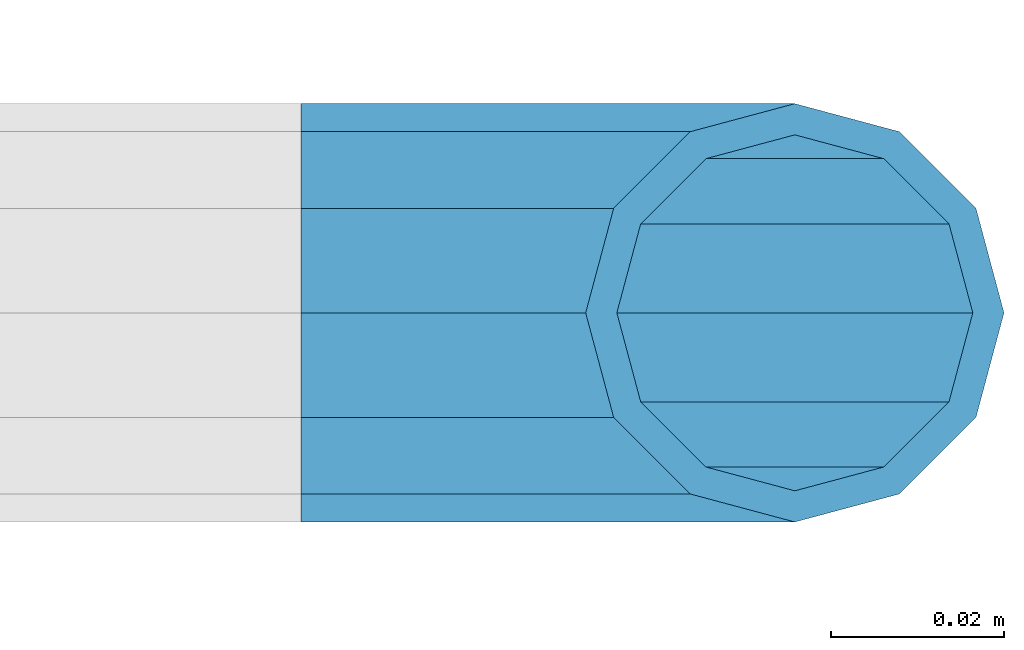
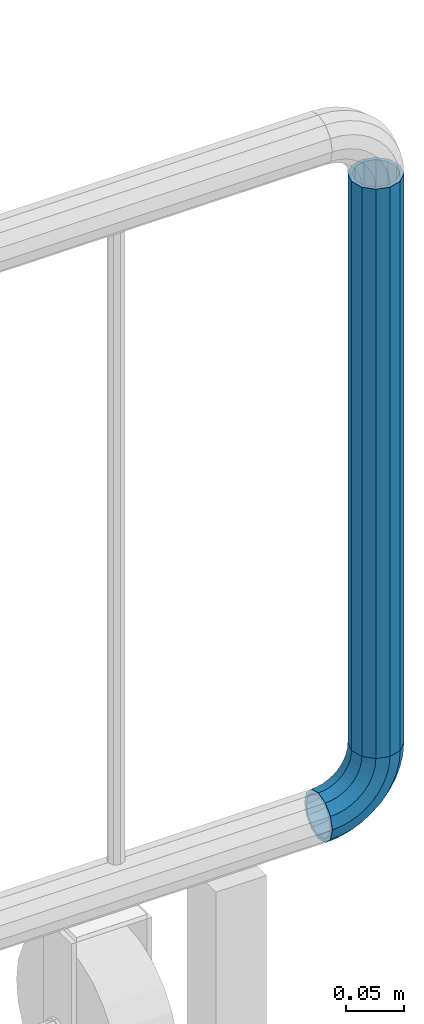
# One storey, part 147 of 208: 1 beam, 1 member.
"""IFC2X3 building model written with IfcOpenShell, lengths in millimetres."""

import ifcopenshell
import ifcopenshell.guid

model = None  # the IFC model being written
_history = None  # IfcOwnerHistory: only IFC2X3 demands one
_inside = {}  # id of a spatial element -> (the spatial element, [elements in it])
_under = {}  # id of a project, library or spatial element -> (it, [spatial elements below it])
_declared = {}  # id of a project -> (the project, [libraries it declares])
_typed = {}  # id of a type object -> (the type object, [elements of that type])
_made_of = {}  # id of a material, layer set ... -> (it, [elements and type objects made of it])


def new_model(schema):
    """Start an empty IFC model of exactly this schema.

    Asked for "IFC4X3", IfcOpenShell would pick the latest addendum, in which some entities
    have other attributes; the version numbers below select the first issue.
    IFC2X3 requires an IfcOwnerHistory on every rooted entity: one is made here for all.
    """
    global model, _history
    if schema == "IFC4X3":
        model = ifcopenshell.file(schema_version=(4, 3, 0, 0))
    else:
        model = ifcopenshell.file(schema=schema)
    _inside.clear()
    _under.clear()
    _declared.clear()
    _typed.clear()
    _made_of.clear()
    _history = None
    if model.schema == "IFC2X3":
        org = make("IfcOrganization", Name="unknown")
        user = make(
            "IfcPersonAndOrganization",
            ThePerson=make("IfcPerson", FamilyName="unknown"),
            TheOrganization=org,
        )
        app = make(
            "IfcApplication",
            ApplicationDeveloper=org,
            Version="unknown",
            ApplicationFullName="unknown",
            ApplicationIdentifier="unknown",
        )
        _history = make(
            "IfcOwnerHistory",
            OwningUser=user,
            OwningApplication=app,
            ChangeAction="ADDED",
            CreationDate=0,
        )
    return model


def make(cls, **values):
    """One entity of the class cls with the attributes given. An attribute that is None is left unset."""
    return model.create_entity(
        cls, **{name: value for name, value in values.items() if value is not None}
    )


def rooted(cls, **values):
    """An entity with a GlobalId (a new one), such as an element, a storey or a relation."""
    return make(cls, GlobalId=ifcopenshell.guid.new(), OwnerHistory=_history, **values)


def si_unit(unit_type, name, prefix=None):
    """IfcSIUnit, for example si_unit("LENGTHUNIT", "METRE", prefix="MILLI")."""
    return make("IfcSIUnit", UnitType=unit_type, Prefix=prefix, Name=name)


def assignment(units):
    """IfcUnitAssignment: the units of a project."""
    return None if units is None else make("IfcUnitAssignment", Units=units)


def point(xyz):
    """IfcCartesianPoint."""
    return None if xyz is None else make("IfcCartesianPoint", Coordinates=xyz)


def direction(xyz):
    """IfcDirection."""
    return None if xyz is None else make("IfcDirection", DirectionRatios=xyz)


def frame(location, z_axis=None, x_axis=None):
    """IfcAxis2Placement3D, a coordinate frame: its origin and axes. An axis left out is left unset."""
    return make(
        "IfcAxis2Placement3D",
        Location=point(location),
        Axis=direction(z_axis),
        RefDirection=direction(x_axis),
    )


def origin_with_axes():
    """The frame at (0, 0, 0) with the z axis (0, 0, 1) and the x axis (1, 0, 0) written out."""
    return frame((0.0, 0.0, 0.0), z_axis=(0.0, 0.0, 1.0), x_axis=(1.0, 0.0, 0.0))


def place(relative_to, where):
    """IfcLocalPlacement: puts the frame where relative to a parent placement (None: the world)."""
    return make(
        "IfcLocalPlacement", PlacementRelTo=relative_to, RelativePlacement=where
    )


def context(
    kind, dimensions, precision=None, world=None, true_north=None, identifier=None
):
    """IfcGeometricRepresentationContext, for example the 3D "Model" context."""
    return make(
        "IfcGeometricRepresentationContext",
        ContextIdentifier=identifier,
        ContextType=kind,
        CoordinateSpaceDimension=dimensions,
        Precision=precision,
        WorldCoordinateSystem=world,
        TrueNorth=true_north,
    )


def subcontext(parent, identifier, kind, view, scale=None):
    """IfcGeometricRepresentationSubContext, for example "Body" below "Model"."""
    return make(
        "IfcGeometricRepresentationSubContext",
        ContextIdentifier=identifier,
        ContextType=kind,
        ParentContext=parent,
        TargetScale=scale,
        TargetView=view,
    )


def project(units=None, contexts=None):
    """IfcProject with its units and contexts."""
    return rooted(
        "IfcProject",
        Name="project",
        RepresentationContexts=contexts,
        UnitsInContext=assignment(units),
    )


def spatial(cls, under=None, at=None, **own):
    """A site, building, storey or space (cls), placed at a placement, below another one or the project."""
    s = rooted(cls, ObjectPlacement=at, **own)
    if under is not None:
        _under.setdefault(under.id(), (under, []))[1].append(s)
    return s


def faces_of(points, faces, orient=None, outer=None):
    """IfcFace entities. A face is a list of loops; a loop is a list of indices into points, from 0.

    orient and outer hold one flag for each loop. By default every Orientation is true, the
    first loop of a face is its IfcFaceOuterBound and the others are IfcFaceBound.
    """
    made = []
    for i, loops in enumerate(faces):
        bounds = []
        for j, loop in enumerate(loops):
            is_outer = j == 0 if outer is None else outer[i][j]
            bounds.append(
                make(
                    "IfcFaceOuterBound" if is_outer else "IfcFaceBound",
                    Bound=make("IfcPolyLoop", Polygon=[points[k] for k in loop]),
                    Orientation=True if orient is None else orient[i][j],
                )
            )
        made.append(make("IfcFace", Bounds=bounds))
    return made


def faceted_brep(points, faces, orient=None, outer=None, voids=None):
    """IfcFacetedBrep: a solid bounded by flat faces; with voids (closed shells), ...WithVoids."""
    shared = [point(p) for p in points]
    hull = make("IfcClosedShell", CfsFaces=faces_of(shared, faces, orient, outer))
    if voids is None:
        return make("IfcFacetedBrep", Outer=hull)
    return make(
        "IfcFacetedBrepWithVoids",
        Outer=hull,
        Voids=[
            make(cls, CfsFaces=faces_of(shared, fs, o, b)) for cls, fs, o, b in voids
        ],
    )


def shape(context_of_items, identifier, shape_type, items):
    """IfcShapeRepresentation: the items that make up one representation, for example the "Body"."""
    return make(
        "IfcShapeRepresentation",
        ContextOfItems=context_of_items,
        RepresentationIdentifier=identifier,
        RepresentationType=shape_type,
        Items=items,
    )


def material(Name=None, Category=None):
    """IfcMaterial."""
    return make("IfcMaterial", Name=Name, Category=Category)


def made_of(thing, what):
    """Note that an element or type object is made of a material, layer set ...; save() writes the relation."""
    if what is not None:
        _made_of.setdefault(what.id(), (what, []))[1].append(thing)
    return thing


def type_object(cls, material=None, **own):
    """A type object (cls), such as IfcWallType, which elements share."""
    return made_of(rooted(cls, **own), material)


def element(
    cls,
    number,
    at=None,
    inside=None,
    cuts=None,
    type_object=None,
    material=None,
    context=None,
    identifier="Body",
    shape_type=None,
    held_by="IfcProductDefinitionShape",
    body=None,
    shapes=None,
    **own,
):
    """One element of the class cls, such as IfcWall. Its Tag is "e" and its number.

    at: its placement. inside: the storey or other place that contains it. cuts: it is an
    opening in that element (IfcRelVoidsElement). A single representation is given by context,
    identifier, shape_type and body (its items); several are given by shapes. held_by: the class
    of the entity that holds the representations. save() writes the other relations.
    """
    e = rooted(cls, Tag="e%d" % number, ObjectPlacement=at, **own)
    if body is not None:
        shapes = [shape(context, identifier, shape_type, body)]
    if shapes is not None:
        e.Representation = make(held_by, Representations=shapes)
    if inside is not None:
        _inside.setdefault(inside.id(), (inside, []))[1].append(e)
    if cuts is not None:
        rooted(
            "IfcRelVoidsElement", RelatingBuildingElement=cuts, RelatedOpeningElement=e
        )
    if type_object is not None:
        _typed.setdefault(type_object.id(), (type_object, []))[1].append(e)
    return made_of(e, material)


def aggregate(whole, parts):
    """IfcRelAggregates: a whole, such as a stair, and the parts it consists of."""
    return rooted("IfcRelAggregates", RelatingObject=whole, RelatedObjects=parts)


def save(model, path):
    """Write the relations noted so far, then the file.

    IfcRelAggregates (storeys below a building ...), IfcRelContainedInSpatialStructure (elements
    in a storey), IfcRelDefinesByType, IfcRelAssociatesMaterial and IfcRelDeclares: one each for
    every whole, place, type object, material and project.
    """
    for whole, parts in _under.values():
        aggregate(whole, parts)
    for where, things in _inside.values():
        rooted(
            "IfcRelContainedInSpatialStructure",
            RelatedElements=things,
            RelatingStructure=where,
        )
    for kind, things in _typed.values():
        rooted("IfcRelDefinesByType", RelatedObjects=things, RelatingType=kind)
    for what, things in _made_of.values():
        rooted("IfcRelAssociatesMaterial", RelatedObjects=things, RelatingMaterial=what)
    for by, libraries in _declared.values():
        rooted("IfcRelDeclares", RelatingContext=by, RelatedDefinitions=libraries)
    model.write(path)


model = new_model("IFC2X3")

# Units and contexts
model_context = context("Model", 3, precision=1e-05, world=origin_with_axes())
body_context = subcontext(model_context, "Body", "Model", "MODEL_VIEW")
ifc_project = project(units=[si_unit("LENGTHUNIT", "METRE", prefix="MILLI"), si_unit("AREAUNIT", "SQUARE_METRE"), si_unit("VOLUMEUNIT", "CUBIC_METRE"), si_unit("MASSUNIT", "GRAM", prefix="KILO"), si_unit("TIMEUNIT", "SECOND"), si_unit("PLANEANGLEUNIT", "RADIAN"), si_unit("SOLIDANGLEUNIT", "STERADIAN"), si_unit("THERMODYNAMICTEMPERATUREUNIT", "DEGREE_CELSIUS"), si_unit("LUMINOUSINTENSITYUNIT", "LUMEN")], contexts=[model_context])

# Site, building, storey
site_placement = place(None, origin_with_axes())
site = spatial("IfcSite", under=ifc_project, at=site_placement, CompositionType="ELEMENT")
building_placement = place(site_placement, origin_with_axes())
building = spatial("IfcBuilding", under=site, at=building_placement, Name="Standard", CompositionType="ELEMENT")
storey_placement = place(building_placement, origin_with_axes())
storey = spatial("IfcBuildingStorey", under=building, at=storey_placement, Name="Undefined", CompositionType="ELEMENT", Elevation=0.0)

# Member
ifc_material = material()
member_type = type_object("IfcMemberType", PredefinedType="NOTDEFINED")
member_placement = place(storey_placement, frame((-12120.0539827644, 2941.85399999618, 281.650006544463), z_axis=(0.0, -1.0, 0.0), x_axis=(-0.707106781186548, 0.0, -0.707106781186548)))
element("IfcMember", 1, at=member_placement, inside=storey, type_object=member_type, material=ifc_material, context=body_context, shape_type="Brep", body=[
    faceted_brep([(17.0766287656552, -17.0766287656552, 0.0), (14.7887943220539, -14.7887943220539, -12.0749999999998), (19.0945697419538, -11.1113146999724, -12.0749999999998), (20.9963409898282, -13.7288782624146, 0.0), (8.53831438282759, -8.53831438282759, -20.9145135013941), (13.8988340683954, -3.95999805533756, -20.9145135013941), (0.0, 0.0, -24.1500000000001), (6.80132714696265, 5.80888215173945, -24.1500000000001), (-8.53831438282759, 8.53831438282759, -20.9145135013941), (-0.296179774470147, 15.5777623588165, -20.9145135013941), (-14.7887943220521, 14.7887943220521, -12.0749999999998), (-5.49191544802852, 22.7290790034513, -12.0749999999998), (-17.0766287656552, 17.0766287656552, 0.0), (-7.39368669589931, 25.3466425658935, 0.0), (-14.7887943220521, 14.7887943220521, 12.0749999999998), (-5.49191544802852, 22.7290790034513, 12.0749999999998), (-8.53831438282759, 8.53831438282759, 20.9145135013941), (-0.296179774470147, 15.5777623588165, 20.9145135013941), (0.0, 0.0, 24.1500000000001), (6.80132714696265, 5.80888215173945, 24.1500000000001), (8.53831438282759, -8.53831438282759, 20.9145135013941), (13.8988340683954, -3.95999805533756, 20.9145135013941), (14.7887943220539, -14.7887943220539, 12.0749999999998), (19.0945697419538, -11.1113146999724, 12.0749999999998), (14.5310443533836, -14.5310443533836, 0.0), (12.5842535535485, -12.5842535535485, 10.2750000000001), (17.2620366843166, -8.58904933077247, 10.2750000000001), (18.8803140815726, -10.8164170826676, 0.0), (7.26552217669268, -7.26552217669268, 17.7968220477701), (12.8408206142685, -2.50376746546499, 17.7968220477701), (0.0, 0.0, 20.5500000000002), (6.80132714696265, 5.80888215173945, 20.5500000000002), (-7.26552217669087, 7.26552217669087, 17.7968220477701), (0.761833679658594, 14.1215317689421, 17.7968220477701), (-12.5842535535485, 12.5842535535485, 10.2750000000001), (-3.65938239039133, 20.2068136342514, 10.2750000000001), (-14.5310443533836, 14.5310443533836, 0.0), (-5.27765978764546, 22.4341813861447, 0.0), (-12.5842535535485, 12.5842535535485, -10.2750000000001), (-3.65938239039133, 20.2068136342514, -10.2750000000001), (-7.26552217669087, 7.26552217669087, -17.7968220477701), (0.761833679658594, 14.1215317689421, -17.7968220477701), (0.0, 0.0, -20.5500000000002), (6.80132714696265, 5.80888215173945, -20.5500000000002), (7.26552217669268, -7.26552217669268, -17.7968220477701), (12.8408206142685, -2.50376746546499, -17.7968220477701), (12.5842535535485, -12.5842535535485, -10.2750000000001), (17.2620366843166, -8.58904933077247, -10.2750000000001), (23.9226184787876, -8.15268262886457, -12.0749999999998), (25.3914986111904, -11.0355222080452, 0.0), (19.9095633268353, -0.27661842847192, -20.9145135013941), (14.4276280424801, 10.482285351105, -24.1500000000001), (8.94569275812501, 21.2411891306783, -20.9145135013941), (4.93263760617265, 29.117253331071, -12.0749999999998), (3.46375747377169, 32.0000929102534, 0.0), (4.93263760617265, 29.117253331071, 12.0749999999998), (8.94569275812501, 21.2411891306783, 20.9145135013941), (14.4276280424801, 10.482285351105, 24.1500000000001), (19.9095633268353, -0.27661842847192, 20.9145135013941), (23.9226184787876, -8.15268262886457, 12.0749999999998), (22.5072161777225, -5.3747992032786, 10.2750000000001), (23.7571328121267, -7.82789872096691, 0.0), (19.0923804273043, 1.32719331506814, 17.7968220477701), (14.4276280424801, 10.482285351105, 20.5500000000002), (9.76287565765597, 19.6373773871383, 17.7968220477701), (6.34803990723776, 26.3393699054886, 10.2750000000001), (5.0981232728318, 28.7924694231751, 0.0), (6.34803990723776, 26.3393699054886, -10.2750000000001), (9.76287565765597, 19.6373773871383, -17.7968220477701), (14.4276280424801, 10.482285351105, -20.5500000000002), (19.0923804273043, 1.32719331506814, -17.7968220477701), (22.5072161777225, -5.3747992032786, -10.2750000000001), (29.1540579492776, -5.98574944945176, -12.0749999999998), (30.1538782624175, -9.06287996733772, 0.0), (26.422498055339, 2.42112746692692, -20.9145135013941), (22.6911178482624, 13.9051349011897, -24.1500000000001), (18.9597376411857, 25.3891423354562, -20.9145135013941), (16.2281777472472, 33.7960192518349, -12.0749999999998), (15.2283574341091, 36.873149769719, 0.0), (16.2281777472472, 33.7960192518349, 12.0749999999998), (18.9597376411857, 25.3891423354562, 20.9145135013941), (22.6911178482624, 13.9051349011897, 24.1500000000001), (26.422498055339, 2.42112746692692, 20.9145135013941), (29.1540579492776, -5.98574944945176, 12.0749999999998), (28.1906383068908, -3.0206486766856, 10.2750000000001), (29.041417082668, -5.63907650867441, 0.0), (25.8662674654661, 4.13302919625858, 17.7968220477701), (22.6911178482624, 13.9051349011897, 20.5500000000002), (19.5159682310605, 23.6772406061227, 17.7968220477701), (17.1915973896339, 30.8309184790687, 10.2750000000001), (16.3408186138568, 33.4493463110575, 0.0), (17.1915973896339, 30.8309184790687, -10.2750000000001), (19.5159682310605, 23.6772406061227, -17.7968220477701), (22.6911178482624, 13.9051349011897, -20.5500000000002), (25.8662674654661, 4.13302919625858, -17.7968220477701), (28.1906383068908, -3.0206486766856, -10.2750000000001), (34.660072751507, -4.66387224825667, -12.0749999999998), (35.1662143510621, -7.85952453908249, 0.0), (33.2772681857005, 4.06681217360347, -20.9145135013941), (31.3883220203406, 15.9931488862876, -24.1500000000001), (29.4993758549808, 27.9194855989754, -20.9145135013941), (28.1165712891743, 36.6501700208355, -12.0749999999998), (27.6104296896192, 39.8458223116613, 0.0), (28.1165712891743, 36.6501700208355, 12.0749999999998), (29.4993758549808, 27.9194855989754, 20.9145135013941), (31.3883220203406, 15.9931488862876, 24.1500000000001), (33.2772681857005, 4.06681217360347, 20.9145135013941), (34.660072751507, -4.66387224825667, 12.0749999999998), (34.1723583568, -1.58456474993909, 10.2750000000001), (34.6030502769172, -4.30384651293934, 0.0), (32.995686148628, 5.84465118667504, 17.7968220477701), (31.3883220203406, 15.9931488862876, 20.5500000000002), (29.7809578920533, 26.1416465859038, 17.7968220477701), (28.6042856838831, 33.5708625225197, 10.2750000000001), (28.1735937637659, 36.29014428552, 0.0), (28.6042856838831, 33.5708625225197, -10.2750000000001), (29.7809578920533, 26.1416465859038, -17.7968220477701), (31.3883220203406, 15.9931488862876, -20.5500000000002), (32.995686148628, 5.84465118667504, -17.7968220477701), (34.1723583568, -1.58456474993909, -10.2750000000001), (40.3050865276346, -4.21960002902779, -12.0749999999998), (40.3050865276346, -7.45508652763237, 0.0), (40.3050865276327, 4.61991347236653, -20.9145135013941), (40.3050865276327, 16.6949134723673, -24.1500000000001), (40.3050865276346, 28.7699134723662, -20.9145135013941), (40.3050865276346, 37.6094269737623, -12.0749999999998), (40.3050865276346, 40.8449134723669, 0.0), (40.3050865276346, 37.6094269737623, 12.0749999999998), (40.3050865276346, 28.7699134723662, 20.9145135013941), (40.3050865276327, 16.6949134723673, 24.1500000000001), (40.3050865276327, 4.61991347236653, 20.9145135013941), (40.3050865276346, -4.21960002902779, 12.0749999999998), (40.3050865276327, -1.10190857540329, 10.2750000000001), (40.3050865276346, -3.85508652763383, 0.0), (40.3050865276346, 6.41991347236763, 17.7968220477701), (40.3050865276327, 16.6949134723673, 20.5500000000002), (40.3050865276346, 26.9699134723669, 17.7968220477701), (40.3050865276346, 34.491735520136, 10.2750000000001), (40.3050865276327, 37.2449134723665, 0.0), (40.3050865276346, 34.491735520136, -10.2750000000001), (40.3050865276346, 26.9699134723669, -17.7968220477701), (40.3050865276327, 16.6949134723673, -20.5500000000002), (40.3050865276346, 6.41991347236763, -17.7968220477701), (40.3050865276327, -1.10190857540329, -10.2750000000001), (45.9501003037603, -4.66387224825485, -12.0749999999998), (45.4439587042052, -7.8595245390843, 0.0), (47.3329048695668, 4.06681217360529, -20.9145135013941), (49.2218510349267, 15.9931488862894, -24.1500000000001), (51.1107972002883, 27.9194855989754, -20.9145135013941), (52.4936017660948, 36.6501700208355, -12.0749999999998), (52.9997433656481, 39.8458223116631, 0.0), (52.4936017660948, 36.6501700208355, 12.0749999999998), (51.1107972002883, 27.9194855989754, 20.9145135013941), (49.2218510349267, 15.9931488862894, 24.1500000000001), (47.3329048695668, 4.06681217360529, 20.9145135013941), (45.9501003037603, -4.66387224825485, 12.0749999999998), (46.4378146984691, -1.58456474993909, 10.2750000000001), (46.0071227783501, -4.30384651294116, 0.0), (47.6144869066393, 5.84465118667322, 17.7968220477701), (49.2218510349267, 15.9931488862894, 20.5500000000002), (50.8292151632158, 26.1416465859038, 17.7968220477701), (52.0058873713861, 33.5708625225197, 10.2750000000001), (52.4365792915032, 36.29014428552, 0.0), (52.0058873713861, 33.5708625225197, -10.2750000000001), (50.8292151632158, 26.1416465859038, -17.7968220477701), (49.2218510349267, 15.9931488862894, -20.5500000000002), (47.6144869066393, 5.84465118667322, -17.7968220477701), (46.4378146984691, -1.58456474993909, -10.2750000000001), (51.4561151059897, -5.98574944945358, -12.0749999999998), (50.4562947928516, -9.06287996733772, 0.0), (54.1876749999301, 2.42112746692692, -20.9145135013941), (57.9190552070068, 13.9051349011897, -24.1500000000001), (61.6504354140834, 25.3891423354562, -20.9145135013941), (64.3819953080219, 33.7960192518349, -12.0749999999998), (65.3818156211601, 36.873149769719, 0.0), (64.3819953080219, 33.7960192518349, 12.0749999999998), (61.6504354140834, 25.3891423354562, 20.9145135013941), (57.9190552070068, 13.9051349011897, 24.1500000000001), (54.1876749999301, 2.42112746692692, 20.9145135013941), (51.4561151059897, -5.98574944945358, 12.0749999999998), (52.4195347483783, -3.0206486766856, 10.2750000000001), (51.5687559726011, -5.63907650867441, 0.0), (54.743905589803, 4.13302919625858, 17.7968220477701), (57.9190552070068, 13.9051349011897, 20.5500000000002), (61.0942048242086, 23.6772406061227, 17.7968220477701), (63.4185756656334, 30.8309184790669, 10.2750000000001), (64.2693544414105, 33.4493463110557, 0.0), (63.4185756656334, 30.8309184790669, -10.2750000000001), (61.0942048242086, 23.6772406061227, -17.7968220477701), (57.9190552070068, 13.9051349011897, -20.5500000000002), (54.743905589803, 4.13302919625858, -17.7968220477701), (52.4195347483783, -3.0206486766856, -10.2750000000001), (56.6875545764815, -8.15268262886457, -12.0749999999998), (55.2186744440787, -11.0355222080452, 0.0), (60.7006097284338, -0.27661842847192, -20.9145135013941), (66.182545012789, 10.482285351105, -24.1500000000001), (71.6644802971441, 21.2411891306783, -20.9145135013941), (75.6775354490965, 29.117253331071, -12.0749999999998), (77.1464155814974, 32.0000929102534, 0.0), (75.6775354490965, 29.117253331071, 12.0749999999998), (71.6644802971441, 21.2411891306783, 20.9145135013941), (66.182545012789, 10.482285351105, 24.1500000000001), (60.7006097284338, -0.27661842847192, 20.9145135013941), (56.6875545764815, -8.15268262886457, 12.0749999999998), (58.1029568775466, -5.3747992032786, 10.2750000000001), (56.8530402431425, -7.82789872096691, 0.0), (61.5177926279648, 1.32719331506814, 17.7968220477701), (66.182545012789, 10.482285351105, 20.5500000000002), (70.8472973976113, 19.6373773871401, 17.7968220477701), (74.2621331480332, 26.3393699054868, 10.2750000000001), (75.5120497824355, 28.7924694231733, 0.0), (74.2621331480332, 26.3393699054868, -10.2750000000001), (70.8472973976113, 19.6373773871401, -17.7968220477701), (66.182545012789, 10.482285351105, -20.5500000000002), (61.5177926279648, 1.32719331506814, -17.7968220477701), (58.1029568775466, -5.3747992032786, -10.2750000000001), (61.5156033133135, -11.1113146999742, -12.0749999999998), (59.6138320654427, -13.7288782624164, 0.0), (66.7113389868737, -3.95999805533756, -20.9145135013941), (73.8088459083046, 5.80888215173763, -24.1500000000001), (80.9063528297374, 15.5777623588183, -20.9145135013941), (86.1020885032976, 22.7290790034513, -12.0749999999998), (88.0038597511684, 25.3466425658935, 0.0), (86.1020885032976, 22.7290790034513, 12.0749999999998), (80.9063528297374, 15.5777623588183, 20.9145135013941), (73.8088459083046, 5.80888215173763, 24.1500000000001), (66.7113389868737, -3.95999805533756, 20.9145135013941), (61.5156033133135, -11.1113146999742, 12.0749999999998), (63.3481363709525, -8.58904933077247, 10.2750000000001), (61.7298589736947, -10.8164170826658, 0.0), (67.7693524409988, -2.50376746546317, 17.7968220477701), (73.8088459083046, 5.80888215173763, 20.5500000000002), (79.8483393756105, 14.1215317689421, 17.7968220477701), (84.2695554456586, 20.2068136342532, 10.2750000000001), (85.8878328429146, 22.4341813861447, 0.0), (84.2695554456586, 20.2068136342532, -10.2750000000001), (79.8483393756105, 14.1215317689421, -17.7968220477701), (73.8088459083046, 5.80888215173763, -20.5500000000002), (67.7693524409988, -2.50376746546317, -17.7968220477701), (63.3481363709525, -8.58904933077247, -10.2750000000001), (65.8213787332152, -14.7887943220539, -12.0749999999998), (63.5335442896121, -17.0766287656534, 0.0), (72.0718586724379, -8.53831438282759, -20.9145135013941), (80.6101730552673, 1.81898940354586e-12, -24.1500000000001), (89.1484874380967, 8.53831438282759, -20.9145135013941), (95.3989673773231, 14.7887943220539, -12.0749999999998), (97.6868018209225, 17.0766287656534, 0.0), (95.3989673773231, 14.7887943220539, 12.0749999999998), (89.1484874380967, 8.53831438282759, 20.9145135013941), (80.6101730552673, 1.81898940354586e-12, 24.1500000000001), (72.0718586724379, -8.53831438282759, 20.9145135013941), (65.8213787332152, -14.7887943220539, 12.0749999999998), (68.0259195017188, -12.5842535535503, 10.2750000000001), (66.0791287018856, -14.5310443533836, 0.0), (73.3446508785764, -7.26552217669268, 17.7968220477701), (80.6101730552673, 1.81898940354586e-12, 20.5500000000002), (87.8756952319582, 7.26552217669268, 17.7968220477701), (93.1944266088158, 12.5842535535503, 10.2750000000001), (95.141217408649, 14.5310443533836, 0.0), (93.1944266088158, 12.5842535535503, -10.2750000000001), (87.8756952319582, 7.26552217669268, -17.7968220477701), (80.6101730552673, 1.81898940354586e-12, -20.5500000000002), (73.3446508785764, -7.26552217669268, -17.7968220477701), (68.0259195017188, -12.5842535535503, -10.2750000000001)], [[[0, 1, 2, 3]], [[1, 4, 5, 2]], [[4, 6, 7, 5]], [[6, 8, 9, 7]], [[8, 10, 11, 9]], [[10, 12, 13, 11]], [[12, 14, 15, 13]], [[14, 16, 17, 15]], [[16, 18, 19, 17]], [[18, 20, 21, 19]], [[20, 22, 23, 21]], [[22, 0, 3, 23]], [[24, 25, 26, 27]], [[25, 28, 29, 26]], [[28, 30, 31, 29]], [[30, 32, 33, 31]], [[32, 34, 35, 33]], [[34, 36, 37, 35]], [[36, 38, 39, 37]], [[38, 40, 41, 39]], [[40, 42, 43, 41]], [[42, 44, 45, 43]], [[44, 46, 47, 45]], [[46, 24, 27, 47]], [[22, 20, 18, 16, 14, 12, 10, 8, 6, 4, 1, 0], [46, 44, 42, 40, 38, 36, 34, 32, 30, 28, 25, 24]], [[3, 2, 48, 49]], [[2, 5, 50, 48]], [[5, 7, 51, 50]], [[7, 9, 52, 51]], [[9, 11, 53, 52]], [[11, 13, 54, 53]], [[13, 15, 55, 54]], [[15, 17, 56, 55]], [[17, 19, 57, 56]], [[19, 21, 58, 57]], [[21, 23, 59, 58]], [[23, 3, 49, 59]], [[27, 26, 60, 61]], [[26, 29, 62, 60]], [[29, 31, 63, 62]], [[31, 33, 64, 63]], [[33, 35, 65, 64]], [[35, 37, 66, 65]], [[37, 39, 67, 66]], [[39, 41, 68, 67]], [[41, 43, 69, 68]], [[43, 45, 70, 69]], [[45, 47, 71, 70]], [[47, 27, 61, 71]], [[49, 48, 72, 73]], [[48, 50, 74, 72]], [[50, 51, 75, 74]], [[51, 52, 76, 75]], [[52, 53, 77, 76]], [[53, 54, 78, 77]], [[54, 55, 79, 78]], [[55, 56, 80, 79]], [[56, 57, 81, 80]], [[57, 58, 82, 81]], [[58, 59, 83, 82]], [[59, 49, 73, 83]], [[61, 60, 84, 85]], [[60, 62, 86, 84]], [[62, 63, 87, 86]], [[63, 64, 88, 87]], [[64, 65, 89, 88]], [[65, 66, 90, 89]], [[66, 67, 91, 90]], [[67, 68, 92, 91]], [[68, 69, 93, 92]], [[69, 70, 94, 93]], [[70, 71, 95, 94]], [[71, 61, 85, 95]], [[73, 72, 96, 97]], [[72, 74, 98, 96]], [[74, 75, 99, 98]], [[75, 76, 100, 99]], [[76, 77, 101, 100]], [[77, 78, 102, 101]], [[78, 79, 103, 102]], [[79, 80, 104, 103]], [[80, 81, 105, 104]], [[81, 82, 106, 105]], [[82, 83, 107, 106]], [[83, 73, 97, 107]], [[85, 84, 108, 109]], [[84, 86, 110, 108]], [[86, 87, 111, 110]], [[87, 88, 112, 111]], [[88, 89, 113, 112]], [[89, 90, 114, 113]], [[90, 91, 115, 114]], [[91, 92, 116, 115]], [[92, 93, 117, 116]], [[93, 94, 118, 117]], [[94, 95, 119, 118]], [[95, 85, 109, 119]], [[97, 96, 120, 121]], [[96, 98, 122, 120]], [[98, 99, 123, 122]], [[99, 100, 124, 123]], [[100, 101, 125, 124]], [[101, 102, 126, 125]], [[102, 103, 127, 126]], [[103, 104, 128, 127]], [[104, 105, 129, 128]], [[105, 106, 130, 129]], [[106, 107, 131, 130]], [[107, 97, 121, 131]], [[109, 108, 132, 133]], [[108, 110, 134, 132]], [[110, 111, 135, 134]], [[111, 112, 136, 135]], [[112, 113, 137, 136]], [[113, 114, 138, 137]], [[114, 115, 139, 138]], [[115, 116, 140, 139]], [[116, 117, 141, 140]], [[117, 118, 142, 141]], [[118, 119, 143, 142]], [[119, 109, 133, 143]], [[121, 120, 144, 145]], [[120, 122, 146, 144]], [[122, 123, 147, 146]], [[123, 124, 148, 147]], [[124, 125, 149, 148]], [[125, 126, 150, 149]], [[126, 127, 151, 150]], [[127, 128, 152, 151]], [[128, 129, 153, 152]], [[129, 130, 154, 153]], [[130, 131, 155, 154]], [[131, 121, 145, 155]], [[133, 132, 156, 157]], [[132, 134, 158, 156]], [[134, 135, 159, 158]], [[135, 136, 160, 159]], [[136, 137, 161, 160]], [[137, 138, 162, 161]], [[138, 139, 163, 162]], [[139, 140, 164, 163]], [[140, 141, 165, 164]], [[141, 142, 166, 165]], [[142, 143, 167, 166]], [[143, 133, 157, 167]], [[145, 144, 168, 169]], [[144, 146, 170, 168]], [[146, 147, 171, 170]], [[147, 148, 172, 171]], [[148, 149, 173, 172]], [[149, 150, 174, 173]], [[150, 151, 175, 174]], [[151, 152, 176, 175]], [[152, 153, 177, 176]], [[153, 154, 178, 177]], [[154, 155, 179, 178]], [[155, 145, 169, 179]], [[157, 156, 180, 181]], [[156, 158, 182, 180]], [[158, 159, 183, 182]], [[159, 160, 184, 183]], [[160, 161, 185, 184]], [[161, 162, 186, 185]], [[162, 163, 187, 186]], [[163, 164, 188, 187]], [[164, 165, 189, 188]], [[165, 166, 190, 189]], [[166, 167, 191, 190]], [[167, 157, 181, 191]], [[169, 168, 192, 193]], [[168, 170, 194, 192]], [[170, 171, 195, 194]], [[171, 172, 196, 195]], [[172, 173, 197, 196]], [[173, 174, 198, 197]], [[174, 175, 199, 198]], [[175, 176, 200, 199]], [[176, 177, 201, 200]], [[177, 178, 202, 201]], [[178, 179, 203, 202]], [[179, 169, 193, 203]], [[181, 180, 204, 205]], [[180, 182, 206, 204]], [[182, 183, 207, 206]], [[183, 184, 208, 207]], [[184, 185, 209, 208]], [[185, 186, 210, 209]], [[186, 187, 211, 210]], [[187, 188, 212, 211]], [[188, 189, 213, 212]], [[189, 190, 214, 213]], [[190, 191, 215, 214]], [[191, 181, 205, 215]], [[193, 192, 216, 217]], [[192, 194, 218, 216]], [[194, 195, 219, 218]], [[195, 196, 220, 219]], [[196, 197, 221, 220]], [[197, 198, 222, 221]], [[198, 199, 223, 222]], [[199, 200, 224, 223]], [[200, 201, 225, 224]], [[201, 202, 226, 225]], [[202, 203, 227, 226]], [[203, 193, 217, 227]], [[205, 204, 228, 229]], [[204, 206, 230, 228]], [[206, 207, 231, 230]], [[207, 208, 232, 231]], [[208, 209, 233, 232]], [[209, 210, 234, 233]], [[210, 211, 235, 234]], [[211, 212, 236, 235]], [[212, 213, 237, 236]], [[213, 214, 238, 237]], [[214, 215, 239, 238]], [[215, 205, 229, 239]], [[217, 216, 240, 241]], [[216, 218, 242, 240]], [[218, 219, 243, 242]], [[219, 220, 244, 243]], [[220, 221, 245, 244]], [[221, 222, 246, 245]], [[222, 223, 247, 246]], [[223, 224, 248, 247]], [[224, 225, 249, 248]], [[225, 226, 250, 249]], [[226, 227, 251, 250]], [[227, 217, 241, 251]], [[229, 228, 252, 253]], [[228, 230, 254, 252]], [[230, 231, 255, 254]], [[231, 232, 256, 255]], [[232, 233, 257, 256]], [[233, 234, 258, 257]], [[234, 235, 259, 258]], [[235, 236, 260, 259]], [[236, 237, 261, 260]], [[237, 238, 262, 261]], [[238, 239, 263, 262]], [[239, 229, 253, 263]], [[242, 243, 244, 245, 246, 247, 248, 249, 250, 251, 241, 240], [254, 255, 256, 257, 258, 259, 260, 261, 262, 263, 253, 252]]]),
])

# Beam
beam_type = type_object("IfcBeamType", PredefinedType="NOTDEFINED")
beam_placement = place(storey_placement, frame((-12120.0539827644, 2941.85399999618, 878.350006544462), z_axis=(1.0, 0.0, 0.0), x_axis=(0.0, 0.0, -1.0)))
element("IfcBeam", 2, at=beam_placement, inside=storey, type_object=beam_type, material=ifc_material, context=body_context, shape_type="Brep", body=[
    faceted_brep([(0.0, -20.5500000000002, 0.0), (0.0, -17.7968220477701, 10.2749999999996), (596.700000000001, -17.7968220477701, 10.2749999999996), (596.700000000001, -20.5500000000002, 0.0), (0.0, -10.2750000000001, 17.7968220477705), (596.700000000001, -10.2750000000001, 17.7968220477705), (0.0, 0.0, 20.5500000000002), (596.700000000001, 0.0, 20.5499999999993), (0.0, 10.2750000000001, 17.7968220477705), (596.700000000001, 10.2750000000001, 17.7968220477705), (0.0, 17.7968220477701, 10.2749999999996), (596.700000000001, 17.7968220477701, 10.2749999999996), (0.0, 20.5500000000002, 0.0), (596.700000000001, 20.5500000000002, 0.0), (0.0, 17.7968220477701, -10.2749999999996), (596.700000000001, 17.7968220477701, -10.2749999999996), (0.0, 10.2750000000001, -17.7968220477705), (596.700000000001, 10.2750000000001, -17.7968220477705), (0.0, 0.0, -20.5500000000002), (596.700000000001, 0.0, -20.5499999999993), (0.0, -10.2750000000001, -17.7968220477705), (596.700000000001, -10.2750000000001, -17.7968220477705), (0.0, -17.7968220477701, -10.2749999999996), (596.700000000001, -17.7968220477701, -10.2749999999996), (0.0, -24.1500000000001, 0.0), (0.0, -20.9145135013941, -12.0750000000007), (596.700000000001, -20.9145135013941, -12.0750000000007), (596.700000000001, -24.1500000000001, 0.0), (0.0, -12.0749999999998, -20.914513501395), (596.700000000001, -12.0749999999998, -20.914513501395), (0.0, 0.0, -24.1500000000001), (596.700000000001, 0.0, -24.1499999999996), (0.0, 12.0749999999998, -20.914513501395), (596.700000000001, 12.0749999999998, -20.914513501395), (0.0, 20.9145135013941, -12.0750000000007), (596.700000000001, 20.9145135013941, -12.0750000000007), (0.0, 24.1500000000001, 0.0), (596.700000000001, 24.1500000000001, 0.0), (0.0, 20.9145135013941, 12.0750000000007), (596.700000000001, 20.9145135013941, 12.0750000000007), (0.0, 12.0749999999998, 20.914513501395), (596.700000000001, 12.0749999999998, 20.914513501395), (0.0, 0.0, 24.1500000000001), (596.700000000001, 0.0, 24.1499999999996), (0.0, -12.0749999999998, 20.914513501395), (596.700000000001, -12.0749999999998, 20.914513501395), (0.0, -20.9145135013941, 12.0750000000007), (596.700000000001, -20.9145135013941, 12.0750000000007)], [[[0, 1, 2, 3]], [[1, 4, 5, 2]], [[4, 6, 7, 5]], [[6, 8, 9, 7]], [[8, 10, 11, 9]], [[10, 12, 13, 11]], [[12, 14, 15, 13]], [[14, 16, 17, 15]], [[16, 18, 19, 17]], [[18, 20, 21, 19]], [[20, 22, 23, 21]], [[22, 0, 3, 23]], [[24, 25, 26, 27]], [[25, 28, 29, 26]], [[28, 30, 31, 29]], [[30, 32, 33, 31]], [[32, 34, 35, 33]], [[34, 36, 37, 35]], [[36, 38, 39, 37]], [[38, 40, 41, 39]], [[40, 42, 43, 41]], [[42, 44, 45, 43]], [[44, 46, 47, 45]], [[46, 24, 27, 47]], [[29, 31, 33, 35, 37, 39, 41, 43, 45, 47, 27, 26], [5, 7, 9, 11, 13, 15, 17, 19, 21, 23, 3, 2]], [[46, 44, 42, 40, 38, 36, 34, 32, 30, 28, 25, 24], [22, 20, 18, 16, 14, 12, 10, 8, 6, 4, 1, 0]]]),
])

save(model, "model.ifc")
